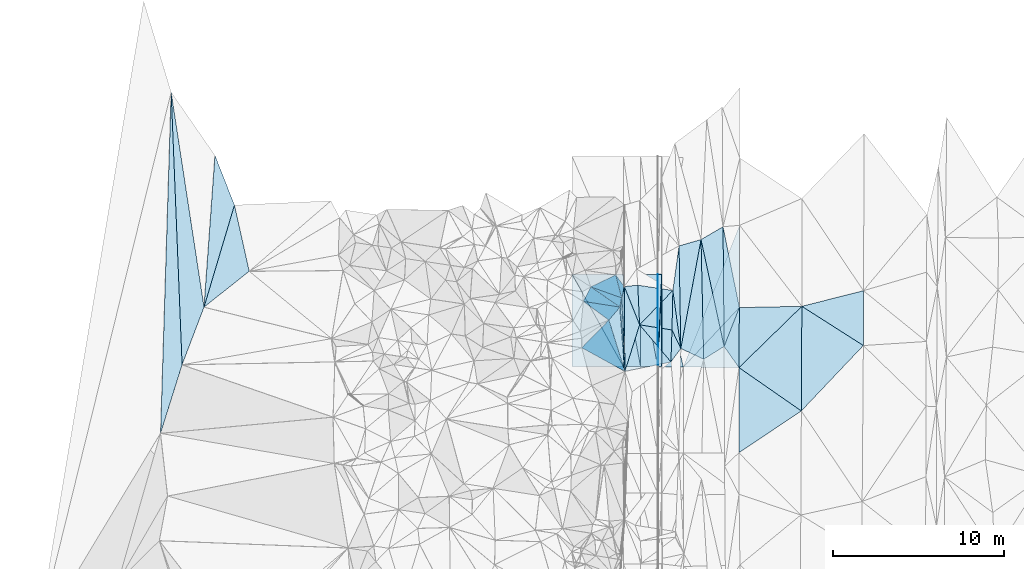
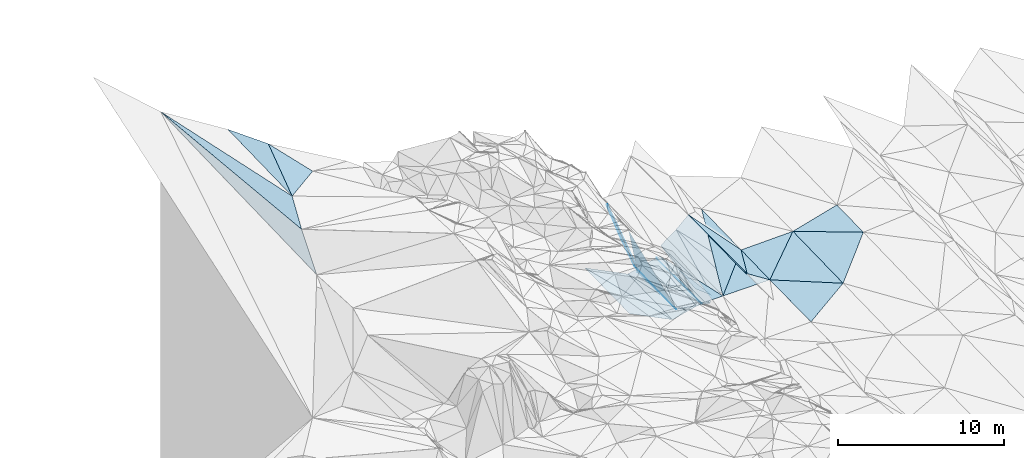
# One storey, part 140 of 275: 46 plates.
"""IFC2X3 building model written with IfcOpenShell, lengths in millimetres."""

import ifcopenshell
import ifcopenshell.guid

model = None  # the IFC model being written
_history = None  # IfcOwnerHistory: only IFC2X3 demands one
_inside = {}  # id of a spatial element -> (the spatial element, [elements in it])
_under = {}  # id of a project, library or spatial element -> (it, [spatial elements below it])
_declared = {}  # id of a project -> (the project, [libraries it declares])
_typed = {}  # id of a type object -> (the type object, [elements of that type])
_made_of = {}  # id of a material, layer set ... -> (it, [elements and type objects made of it])


def new_model(schema):
    """Start an empty IFC model of exactly this schema.

    Asked for "IFC4X3", IfcOpenShell would pick the latest addendum, in which some entities
    have other attributes; the version numbers below select the first issue.
    IFC2X3 requires an IfcOwnerHistory on every rooted entity: one is made here for all.
    """
    global model, _history
    if schema == "IFC4X3":
        model = ifcopenshell.file(schema_version=(4, 3, 0, 0))
    else:
        model = ifcopenshell.file(schema=schema)
    _inside.clear()
    _under.clear()
    _declared.clear()
    _typed.clear()
    _made_of.clear()
    _history = None
    if model.schema == "IFC2X3":
        org = make("IfcOrganization", Name="unknown")
        user = make(
            "IfcPersonAndOrganization",
            ThePerson=make("IfcPerson", FamilyName="unknown"),
            TheOrganization=org,
        )
        app = make(
            "IfcApplication",
            ApplicationDeveloper=org,
            Version="unknown",
            ApplicationFullName="unknown",
            ApplicationIdentifier="unknown",
        )
        _history = make(
            "IfcOwnerHistory",
            OwningUser=user,
            OwningApplication=app,
            ChangeAction="ADDED",
            CreationDate=0,
        )
    return model


def make(cls, **values):
    """One entity of the class cls with the attributes given. An attribute that is None is left unset."""
    return model.create_entity(
        cls, **{name: value for name, value in values.items() if value is not None}
    )


def rooted(cls, **values):
    """An entity with a GlobalId (a new one), such as an element, a storey or a relation."""
    return make(cls, GlobalId=ifcopenshell.guid.new(), OwnerHistory=_history, **values)


def si_unit(unit_type, name, prefix=None):
    """IfcSIUnit, for example si_unit("LENGTHUNIT", "METRE", prefix="MILLI")."""
    return make("IfcSIUnit", UnitType=unit_type, Prefix=prefix, Name=name)


def assignment(units):
    """IfcUnitAssignment: the units of a project."""
    return None if units is None else make("IfcUnitAssignment", Units=units)


def point(xyz):
    """IfcCartesianPoint."""
    return None if xyz is None else make("IfcCartesianPoint", Coordinates=xyz)


def direction(xyz):
    """IfcDirection."""
    return None if xyz is None else make("IfcDirection", DirectionRatios=xyz)


def frame(location, z_axis=None, x_axis=None):
    """IfcAxis2Placement3D, a coordinate frame: its origin and axes. An axis left out is left unset."""
    return make(
        "IfcAxis2Placement3D",
        Location=point(location),
        Axis=direction(z_axis),
        RefDirection=direction(x_axis),
    )


def origin_with_axes():
    """The frame at (0, 0, 0) with the z axis (0, 0, 1) and the x axis (1, 0, 0) written out."""
    return frame((0.0, 0.0, 0.0), z_axis=(0.0, 0.0, 1.0), x_axis=(1.0, 0.0, 0.0))


def place(relative_to, where):
    """IfcLocalPlacement: puts the frame where relative to a parent placement (None: the world)."""
    return make(
        "IfcLocalPlacement", PlacementRelTo=relative_to, RelativePlacement=where
    )


def context(
    kind, dimensions, precision=None, world=None, true_north=None, identifier=None
):
    """IfcGeometricRepresentationContext, for example the 3D "Model" context."""
    return make(
        "IfcGeometricRepresentationContext",
        ContextIdentifier=identifier,
        ContextType=kind,
        CoordinateSpaceDimension=dimensions,
        Precision=precision,
        WorldCoordinateSystem=world,
        TrueNorth=true_north,
    )


def subcontext(parent, identifier, kind, view, scale=None):
    """IfcGeometricRepresentationSubContext, for example "Body" below "Model"."""
    return make(
        "IfcGeometricRepresentationSubContext",
        ContextIdentifier=identifier,
        ContextType=kind,
        ParentContext=parent,
        TargetScale=scale,
        TargetView=view,
    )


def project(units=None, contexts=None):
    """IfcProject with its units and contexts."""
    return rooted(
        "IfcProject",
        Name="project",
        RepresentationContexts=contexts,
        UnitsInContext=assignment(units),
    )


def spatial(cls, under=None, at=None, **own):
    """A site, building, storey or space (cls), placed at a placement, below another one or the project."""
    s = rooted(cls, ObjectPlacement=at, **own)
    if under is not None:
        _under.setdefault(under.id(), (under, []))[1].append(s)
    return s


def polyline(points):
    """IfcPolyline through the points."""
    return make("IfcPolyline", Points=[point(p) for p in points])


def outline(outer, holes=None, kind="AREA"):
    """IfcArbitraryClosedProfileDef: a profile drawn as a closed curve; with holes, ...WithVoids."""
    if holes is None:
        return make("IfcArbitraryClosedProfileDef", ProfileType=kind, OuterCurve=outer)
    return make(
        "IfcArbitraryProfileDefWithVoids",
        ProfileType=kind,
        OuterCurve=outer,
        InnerCurves=holes,
    )


def extrude(swept, where, along, depth):
    """IfcExtrudedAreaSolid: the profile swept, set in the frame where, extruded along a direction by depth."""
    return make(
        "IfcExtrudedAreaSolid",
        SweptArea=swept,
        Position=where,
        ExtrudedDirection=direction(along),
        Depth=depth,
    )


def shape(context_of_items, identifier, shape_type, items):
    """IfcShapeRepresentation: the items that make up one representation, for example the "Body"."""
    return make(
        "IfcShapeRepresentation",
        ContextOfItems=context_of_items,
        RepresentationIdentifier=identifier,
        RepresentationType=shape_type,
        Items=items,
    )


def material(Name=None, Category=None):
    """IfcMaterial."""
    return make("IfcMaterial", Name=Name, Category=Category)


def made_of(thing, what):
    """Note that an element or type object is made of a material, layer set ...; save() writes the relation."""
    if what is not None:
        _made_of.setdefault(what.id(), (what, []))[1].append(thing)
    return thing


def type_object(cls, material=None, **own):
    """A type object (cls), such as IfcWallType, which elements share."""
    return made_of(rooted(cls, **own), material)


def element(
    cls,
    number,
    at=None,
    inside=None,
    cuts=None,
    type_object=None,
    material=None,
    context=None,
    identifier="Body",
    shape_type=None,
    held_by="IfcProductDefinitionShape",
    body=None,
    shapes=None,
    **own,
):
    """One element of the class cls, such as IfcWall. Its Tag is "e" and its number.

    at: its placement. inside: the storey or other place that contains it. cuts: it is an
    opening in that element (IfcRelVoidsElement). A single representation is given by context,
    identifier, shape_type and body (its items); several are given by shapes. held_by: the class
    of the entity that holds the representations. save() writes the other relations.
    """
    e = rooted(cls, Tag="e%d" % number, ObjectPlacement=at, **own)
    if body is not None:
        shapes = [shape(context, identifier, shape_type, body)]
    if shapes is not None:
        e.Representation = make(held_by, Representations=shapes)
    if inside is not None:
        _inside.setdefault(inside.id(), (inside, []))[1].append(e)
    if cuts is not None:
        rooted(
            "IfcRelVoidsElement", RelatingBuildingElement=cuts, RelatedOpeningElement=e
        )
    if type_object is not None:
        _typed.setdefault(type_object.id(), (type_object, []))[1].append(e)
    return made_of(e, material)


def aggregate(whole, parts):
    """IfcRelAggregates: a whole, such as a stair, and the parts it consists of."""
    return rooted("IfcRelAggregates", RelatingObject=whole, RelatedObjects=parts)


def save(model, path):
    """Write the relations noted so far, then the file.

    IfcRelAggregates (storeys below a building ...), IfcRelContainedInSpatialStructure (elements
    in a storey), IfcRelDefinesByType, IfcRelAssociatesMaterial and IfcRelDeclares: one each for
    every whole, place, type object, material and project.
    """
    for whole, parts in _under.values():
        aggregate(whole, parts)
    for where, things in _inside.values():
        rooted(
            "IfcRelContainedInSpatialStructure",
            RelatedElements=things,
            RelatingStructure=where,
        )
    for kind, things in _typed.values():
        rooted("IfcRelDefinesByType", RelatedObjects=things, RelatingType=kind)
    for what, things in _made_of.values():
        rooted("IfcRelAssociatesMaterial", RelatedObjects=things, RelatingMaterial=what)
    for by, libraries in _declared.values():
        rooted("IfcRelDeclares", RelatingContext=by, RelatedDefinitions=libraries)
    model.write(path)


model = new_model("IFC2X3")

# Units and contexts
model_context = context("Model", 3, precision=1e-05, world=origin_with_axes())
body_context = subcontext(model_context, "Body", "Model", "MODEL_VIEW")
ifc_project = project(units=[si_unit("LENGTHUNIT", "METRE", prefix="MILLI"), si_unit("AREAUNIT", "SQUARE_METRE"), si_unit("VOLUMEUNIT", "CUBIC_METRE"), si_unit("MASSUNIT", "GRAM", prefix="KILO"), si_unit("TIMEUNIT", "SECOND"), si_unit("PLANEANGLEUNIT", "RADIAN"), si_unit("SOLIDANGLEUNIT", "STERADIAN"), si_unit("THERMODYNAMICTEMPERATUREUNIT", "DEGREE_CELSIUS"), si_unit("LUMINOUSINTENSITYUNIT", "LUMEN")], contexts=[model_context])

# Site, building, storey
site_placement = place(None, origin_with_axes())
site = spatial("IfcSite", under=ifc_project, at=site_placement, CompositionType="ELEMENT")
building_placement = place(site_placement, origin_with_axes())
building = spatial("IfcBuilding", under=site, at=building_placement, Name="Undefined", CompositionType="ELEMENT")
storey_placement = place(building_placement, origin_with_axes())
storey = spatial("IfcBuildingStorey", under=building, at=storey_placement, Name="Undefined", CompositionType="ELEMENT", Elevation=0.0)

# Plates
ifc_material = material()
plate_type_1 = type_object("IfcPlateType", PredefinedType="NOTDEFINED")
plate_1_placement = place(storey_placement, frame((-95661.8990980026, 131994.425221321, 43600.5627120772), z_axis=(0.0499218416965569, 0.018987695683645, -0.998572619860093), x_axis=(0.998752315665235, 0.000325866070990781, 0.0499370179790064)))
element("IfcPlate", 1, at=plate_1_placement, inside=storey, type_object=plate_type_1, material=ifc_material, Name="00_PR", context=body_context, shape_type="SweptSolid", body=[
    extrude(outline(polyline([(0.0, 0.0), (20.0252170562744, 7.18500814400613e-11), (14.8728761672974, 5399.20458984375), (0.0, 0.0)])), frame((-8.85201319254618e-08, 2.18876761149539e-07, -0.5000001331573), z_axis=(0.0, 0.0, 1.0), x_axis=(1.0, 0.0, 0.0)), (0.0, 0.0, 1.0), 1.0),
])
plate_2_placement = place(storey_placement, frame((-95640.1682808377, 126596.199078681, 43499.002711449), z_axis=(0.0499218416965569, 0.018987695683645, -0.998572619860093), x_axis=(-0.998752315521962, -0.000325847078123489, -0.0499370209684242)))
element("IfcPlate", 2, at=plate_2_placement, inside=storey, type_object=plate_type_1, material=ifc_material, Name="00_PR", context=body_context, shape_type="SweptSolid", body=[
    extrude(outline(polyline([(0.0, 0.0), (20.0252170562744, 7.18500814400613e-11), (14.8730592727661, 5399.20458984375), (0.0, 0.0)])), frame((-8.85201319254618e-08, 2.18876761149539e-07, -0.5000001331573), z_axis=(0.0, 0.0, 1.0), x_axis=(1.0, 0.0, 0.0)), (0.0, 0.0, 1.0), 1.0),
])
plate_type_2 = type_object("IfcPlateType", PredefinedType="NOTDEFINED")
plate_3_placement = place(storey_placement, frame((-97863.179340422, 130077.496408482, 44289.6938578269), z_axis=(-0.790668284367022, -0.00121570864012599, -0.61224356766618), x_axis=(0.0757211073899815, -0.992514641650696, -0.0958175349538129)))
element("IfcPlate", 3, at=plate_3_placement, inside=storey, type_object=plate_type_2, material=ifc_material, Name="00", context=body_context, shape_type="SweptSolid", body=[
    extrude(outline(polyline([(0.0, 0.0), (3788.45068359375, -1.07684172689915e-09), (621.871643066406, 1146.20056152344), (0.0, 0.0)])), frame((-8.85201319254618e-08, 2.18876761149539e-07, -0.5000001331573), z_axis=(0.0, 0.0, 1.0), x_axis=(1.0, 0.0, 0.0)), (0.0, 0.0, 1.0), 1.0),
])
plate_type_3 = type_object("IfcPlateType", PredefinedType="NOTDEFINED")
plate_4_placement = place(storey_placement, frame((-120390.848597019, 136038.449160367, 58200.5032237032), z_axis=(-0.109542996135364, -0.030647323388409, -0.993509473315083), x_axis=(0.218084760553901, -0.975911025166168, 0.00605872703353124)))
element("IfcPlate", 4, at=plate_4_placement, inside=storey, type_object=plate_type_3, material=ifc_material, Name="00", context=body_context, shape_type="SweptSolid", body=[
    extrude(outline(polyline([(0.0, 0.0), (3961.22827148438, -4.1094608604908e-08), (5431.02783203125, 3055.7373046875), (0.0, 0.0)])), frame((-8.85201319254618e-08, 2.18876761149539e-07, -0.5000001331573), z_axis=(0.0, 0.0, 1.0), x_axis=(1.0, 0.0, 0.0)), (0.0, 0.0, 1.0), 1.0),
])
plate_type_4 = type_object("IfcPlateType", PredefinedType="NOTDEFINED")
for number, where, z_axis, x_axis, name in (
    (5, (-95640.1682808377, 126596.199078681, 43499.002711449), (0.0499218416965569, 0.018987695683645, -0.998572619860093), (0.0422380869159654, 0.9988846335438, 0.0211052809445606), "00_PR"),
    (6, (-95411.8995216493, 131994.505833605, 43613.0627106872), (0.0499218416965569, 0.018987695683645, -0.998572619860093), (-0.042238086915738, -0.998884633543988, -0.0211052809360945), "00_PR"),
):
    element("IfcPlate", number, at=place(storey_placement, frame(where, z_axis=z_axis, x_axis=x_axis)), inside=storey, type_object=plate_type_4, material=ifc_material, Name=name, context=body_context, shape_type="SweptSolid", body=[
        extrude(outline(polyline([(0.0, 0.0), (5404.33447265625, -3.89991328120232e-09), (10.0314474105835, 230.068084716797), (0.0, 0.0)])), frame((-8.85201319254618e-08, 2.18876761149539e-07, -0.5000001331573), z_axis=(0.0, 0.0, 1.0), x_axis=(1.0, 0.0, 0.0)), (0.0, 0.0, 1.0), 1.0),
    ])
plate_type_5 = type_object("IfcPlateType", PredefinedType="NOTDEFINED")
plate_5_placement = place(storey_placement, frame((-94823.4613389008, 128742.419038902, 42979.5019184883), z_axis=(-0.0783408175481711, -0.04016436048198, -0.99611723228391), x_axis=(0.430857008612677, -0.902416745782213, 0.00250101203026424)))
element("IfcPlate", 7, at=plate_5_placement, inside=storey, type_object=plate_type_5, material=ifc_material, Name="00", context=body_context, shape_type="SweptSolid", body=[
    extrude(outline(polyline([(0.0, 0.0), (1199.51452636719, -4.60568116977811e-09), (1655.84497070313, 862.019409179688), (0.0, 0.0)])), frame((-8.85201319254618e-08, 2.18876761149539e-07, -0.5000001331573), z_axis=(0.0, 0.0, 1.0), x_axis=(1.0, 0.0, 0.0)), (0.0, 0.0, 1.0), 1.0),
])
plate_type_6 = type_object("IfcPlateType", PredefinedType="NOTDEFINED")
plate_6_placement = place(storey_placement, frame((-100662.146809664, 131992.821665722, 44600.6148496057), z_axis=(-0.447154492281629, 0.0168472491289806, -0.894298065652132), x_axis=(0.894427130836624, 0.000286740053144665, -0.447213623901941)))
element("IfcPlate", 8, at=plate_6_placement, inside=storey, type_object=plate_type_6, material=ifc_material, Name="00_PR", context=body_context, shape_type="SweptSolid", body=[
    extrude(outline(polyline([(0.0, 0.0), (3354.10180664063, 1.95868778973818e-08), (3399.96801757813, 5399.01220703125), (0.0, 0.0)])), frame((-8.85201319254618e-08, 2.18876761149539e-07, -0.5000001331573), z_axis=(0.0, 0.0, 1.0), x_axis=(1.0, 0.0, 0.0)), (0.0, 0.0, 1.0), 1.0),
])
plate_7_placement = place(storey_placement, frame((-97660.4166155933, 126595.550751445, 42998.0548495893), z_axis=(-0.447154492281629, 0.0168472491289806, -0.894298065652132), x_axis=(-0.894427130836978, -0.000286740047867567, 0.447213623901237)))
element("IfcPlate", 9, at=plate_7_placement, inside=storey, type_object=plate_type_6, material=ifc_material, Name="00_PR", context=body_context, shape_type="SweptSolid", body=[
    extrude(outline(polyline([(0.0, 0.0), (3354.1025390625, 9.64791979640722e-09), (3399.96728515625, 5399.0126953125), (0.0, 0.0)])), frame((-8.85201319254618e-08, 2.18876761149539e-07, -0.5000001331573), z_axis=(0.0, 0.0, 1.0), x_axis=(1.0, 0.0, 0.0)), (0.0, 0.0, 1.0), 1.0),
])
plate_type_7 = type_object("IfcPlateType", PredefinedType="NOTDEFINED")
plate_8_placement = place(storey_placement, frame((-96660.0726741752, 126595.872203827, 43248.0170096413), z_axis=(0.242488705228662, 0.0185061610069776, -0.969977705847568), x_axis=(-0.970142403271045, -0.000311047105442569, -0.242535813077531)))
element("IfcPlate", 10, at=plate_8_placement, inside=storey, type_object=plate_type_7, material=ifc_material, Name="00_PR", context=body_context, shape_type="SweptSolid", body=[
    extrude(outline(polyline([(0.0, 0.0), (1030.77563476563, 6.37373887002468e-09), (1005.90093994141, 5399.14990234375), (0.0, 0.0)])), frame((-8.85201319254618e-08, 2.18876761149539e-07, -0.5000001331573), z_axis=(0.0, 0.0, 1.0), x_axis=(1.0, 0.0, 0.0)), (0.0, 0.0, 1.0), 1.0),
])
plate_9_placement = place(storey_placement, frame((-95660.0722308411, 126596.192312802, 43498.0170093509), z_axis=(0.242488705228662, 0.0185061610069776, -0.969977705847568), x_axis=(-0.970142403271045, -0.000311047105442569, -0.242535813077531)))
element("IfcPlate", 11, at=plate_9_placement, inside=storey, type_object=plate_type_7, material=ifc_material, Name="00_PR", context=body_context, shape_type="SweptSolid", body=[
    extrude(outline(polyline([(0.0, 0.0), (1030.77685546875, 5.06406649947166e-09), (1005.90490722656, 5399.14990234375), (0.0, 0.0)])), frame((-8.85201319254618e-08, 2.18876761149539e-07, -0.5000001331573), z_axis=(0.0, 0.0, 1.0), x_axis=(1.0, 0.0, 0.0)), (0.0, 0.0, 1.0), 1.0),
])
plate_10_placement = place(storey_placement, frame((-97661.8023938681, 131993.784248121, 43100.5770082104), z_axis=(0.242488705228662, 0.0185061610069776, -0.969977705847568), x_axis=(0.970142455388523, 0.000311440077304942, 0.242535604103411)))
element("IfcPlate", 12, at=plate_10_placement, inside=storey, type_object=plate_type_7, material=ifc_material, Name="00_PR", context=body_context, shape_type="SweptSolid", body=[
    extrude(outline(polyline([(0.0, 0.0), (1030.77563476563, 6.37373887002468e-09), (1005.90093994141, 5399.14990234375), (0.0, 0.0)])), frame((-8.85201319254618e-08, 2.18876761149539e-07, -0.5000001331573), z_axis=(0.0, 0.0, 1.0), x_axis=(1.0, 0.0, 0.0)), (0.0, 0.0, 1.0), 1.0),
])
plate_11_placement = place(storey_placement, frame((-95660.0722308411, 126596.192312802, 43498.0170093509), z_axis=(0.242488705228662, 0.0185061610069776, -0.969977705847568), x_axis=(-0.182396408137149, 0.982858504377498, -0.0268460550452826)))
element("IfcPlate", 13, at=plate_11_placement, inside=storey, type_object=plate_type_7, material=ifc_material, Name="00_PR", context=body_context, shape_type="SweptSolid", body=[
    extrude(outline(polyline([(0.0, 0.0), (5492.0546875, 2.69646989181638e-08), (5303.26123046875, 1013.34002685547), (0.0, 0.0)])), frame((-8.85201319254618e-08, 2.18876761149539e-07, -0.5000001331573), z_axis=(0.0, 0.0, 1.0), x_axis=(1.0, 0.0, 0.0)), (0.0, 0.0, 1.0), 1.0),
])
plate_type_8 = type_object("IfcPlateType", PredefinedType="NOTDEFINED")
plate_12_placement = place(storey_placement, frame((-97612.1278846414, 131282.944115251, 44127.663024008), z_axis=(-0.738487986327244, 0.0219489512718493, -0.673909294778161), x_axis=(0.00721172458118886, -0.999155744242152, -0.0404448980277686)))
element("IfcPlate", 14, at=plate_12_placement, inside=storey, type_object=plate_type_8, material=ifc_material, Name="00", context=body_context, shape_type="SweptSolid", body=[
    extrude(outline(polyline([(0.0, 0.0), (4969.724609375, -5.40312612429261e-08), (661.130981445313, 228.735198974609), (0.0, 0.0)])), frame((-8.85201319254618e-08, 2.18876761149539e-07, -0.5000001331573), z_axis=(0.0, 0.0, 1.0), x_axis=(1.0, 0.0, 0.0)), (0.0, 0.0, 1.0), 1.0),
])
plate_type_9 = type_object("IfcPlateType", PredefinedType="NOTDEFINED")
plate_13_placement = place(storey_placement, frame((-94160.1732957976, 126572.965089618, 43538.2812143713), z_axis=(0.0225676012123619, 0.0189977767902863, -0.999564799226417), x_axis=(-0.999579491036993, 0.0186384849298618, -0.0222136889719966)))
element("IfcPlate", 15, at=plate_13_placement, inside=storey, type_object=plate_type_9, material=ifc_material, Name="00_PR", context=body_context, shape_type="SweptSolid", body=[
    extrude(outline(polyline([(0.0, 0.0), (1250.53515625, 2.48837750405073e-09), (1350.60168457031, 5398.27978515625), (0.0, 0.0)])), frame((-8.85201319254618e-08, 2.18876761149539e-07, -0.5000001331573), z_axis=(0.0, 0.0, 1.0), x_axis=(1.0, 0.0, 0.0)), (0.0, 0.0, 1.0), 1.0),
])
plate_type_10 = type_object("IfcPlateType", PredefinedType="NOTDEFINED")
plate_14_placement = place(storey_placement, frame((-90868.8061363203, 134858.756942, 43772.0302122336), z_axis=(0.0220145554295326, 0.0194537974897408, -0.999568361400294), x_axis=(-0.00365214192346392, -0.99980242929502, -0.019538787965144)))
element("IfcPlate", 16, at=plate_14_placement, inside=storey, type_object=plate_type_10, material=ifc_material, Name="00_PR", context=body_context, shape_type="SweptSolid", body=[
    extrude(outline(polyline([(0.0, 0.0), (4808.5888671875, -6.93980837240815e-08), (8300.7421875, 3261.8642578125), (0.0, 0.0)])), frame((-8.85201319254618e-08, 2.18876761149539e-07, -0.5000001331573), z_axis=(0.0, 0.0, 1.0), x_axis=(1.0, 0.0, 0.0)), (0.0, 0.0, 1.0), 1.0),
])
plate_type_11 = type_object("IfcPlateType", PredefinedType="NOTDEFINED")
plate_15_placement = place(storey_placement, frame((-90886.3677518912, 130051.118030396, 43678.0762124378), z_axis=(0.0220835300894466, 0.0193888651768907, -0.999568101534828), x_axis=(-0.0065915929099637, -0.999787371529886, -0.0195387469473334)))
element("IfcPlate", 17, at=plate_15_placement, inside=storey, type_object=plate_type_11, material=ifc_material, Name="00_PR", context=body_context, shape_type="SweptSolid", body=[
    extrude(outline(polyline([(0.0, 0.0), (3509.74389648438, 1.25291990116239e-08), (3501.72412109375, 3251.58740234375), (0.0, 0.0)])), frame((-8.85201319254618e-08, 2.18876761149539e-07, -0.5000001331573), z_axis=(0.0, 0.0, 1.0), x_axis=(1.0, 0.0, 0.0)), (0.0, 0.0, 1.0), 1.0),
])
plate_type_12 = type_object("IfcPlateType", PredefinedType="NOTDEFINED")
plate_16_placement = place(storey_placement, frame((-98114.4141413349, 131956.453214629, 45819.834015457), z_axis=(-0.933140588245318, 0.138105686779731, -0.331926892324623), x_axis=(0.265838928305538, -0.356498279862591, -0.895677754916564)))
element("IfcPlate", 18, at=plate_16_placement, inside=storey, type_object=plate_type_12, material=ifc_material, Name="00", context=body_context, shape_type="SweptSolid", body=[
    extrude(outline(polyline([(0.0, 0.0), (1889.072265625, -2.7212081477046e-09), (1960.48083496094, 695.927307128906), (0.0, 0.0)])), frame((-8.85201319254618e-08, 2.18876761149539e-07, -0.5000001331573), z_axis=(0.0, 0.0, 1.0), x_axis=(1.0, 0.0, 0.0)), (0.0, 0.0, 1.0), 1.0),
])
plate_type_13 = type_object("IfcPlateType", PredefinedType="NOTDEFINED")
plate_17_placement = place(storey_placement, frame((-97863.2443082038, 130077.580927324, 44289.8236715138), z_axis=(-0.920595210166484, 0.167829841706515, -0.352615375801019), x_axis=(-0.348481156374074, 0.0544786368970685, 0.935731244414776)))
element("IfcPlate", 19, at=plate_17_placement, inside=storey, type_object=plate_type_13, material=ifc_material, Name="00", context=body_context, shape_type="SweptSolid", body=[
    extrude(outline(polyline([(0.0, 0.0), (6134.23974609375, 1.1146767064929e-08), (5346.04150390625, 905.120300292969), (0.0, 0.0)])), frame((-8.85201319254618e-08, 2.18876761149539e-07, -0.5000001331573), z_axis=(0.0, 0.0, 1.0), x_axis=(1.0, 0.0, 0.0)), (0.0, 0.0, 1.0), 1.0),
])
plate_type_14 = type_object("IfcPlateType", PredefinedType="NOTDEFINED")
plate_18_placement = place(storey_placement, frame((-94411.4847820589, 133654.498374057, 43059.5079749297), z_axis=(-0.177884222103543, 0.00952994301497235, -0.984005276262657), x_axis=(0.0174773486148488, -0.999764784341978, -0.0128420510446195)))
element("IfcPlate", 20, at=plate_18_placement, inside=storey, type_object=plate_type_14, material=ifc_material, Name="00", context=body_context, shape_type="SweptSolid", body=[
    extrude(outline(polyline([(0.0, 0.0), (5995.9267578125, -4.41359588876367e-08), (2596.8369140625, 412.823272705078), (0.0, 0.0)])), frame((-8.85201319254618e-08, 2.18876761149539e-07, -0.5000001331573), z_axis=(0.0, 0.0, 1.0), x_axis=(1.0, 0.0, 0.0)), (0.0, 0.0, 1.0), 1.0),
])
plate_type_15 = type_object("IfcPlateType", PredefinedType="NOTDEFINED")
plate_19_placement = place(storey_placement, frame((-96716.6297522672, 129042.645744843, 43779.5308324078), z_axis=(-0.345445783626743, 0.016738339117702, -0.938289421542248), x_axis=(-0.0453271786313886, 0.998376344303925, 0.034498145046499)))
element("IfcPlate", 21, at=plate_19_placement, inside=storey, type_object=plate_type_15, material=ifc_material, Name="00", context=body_context, shape_type="SweptSolid", body=[
    extrude(outline(polyline([(0.0, 0.0), (2318.96533203125, -3.18686943501234e-09), (1892.74072265625, 2165.763671875), (0.0, 0.0)])), frame((-8.85201319254618e-08, 2.18876761149539e-07, -0.5000001331573), z_axis=(0.0, 0.0, 1.0), x_axis=(1.0, 0.0, 0.0)), (0.0, 0.0, 1.0), 1.0),
])
plate_type_16 = type_object("IfcPlateType", PredefinedType="NOTDEFINED")
plate_20_placement = place(storey_placement, frame((-97761.4351360014, 130614.442654695, 44269.5540765426), z_axis=(-0.449444516817921, 0.0518058851599099, -0.891804786130408), x_axis=(0.0429447604263251, -0.995909669650746, -0.0794963989628941)))
element("IfcPlate", 22, at=plate_20_placement, inside=storey, type_object=plate_type_16, material=ifc_material, Name="00", context=body_context, shape_type="SweptSolid", body=[
    extrude(outline(polyline([(0.0, 0.0), (4314.66064453125, -1.19616743177176e-08), (528.771545410156, 139.286117553711), (0.0, 0.0)])), frame((-8.85201319254618e-08, 2.18876761149539e-07, -0.5000001331573), z_axis=(0.0, 0.0, 1.0), x_axis=(1.0, 0.0, 0.0)), (0.0, 0.0, 1.0), 1.0),
])
plate_type_17 = type_object("IfcPlateType", PredefinedType="NOTDEFINED")
plate_21_placement = place(storey_placement, frame((-100000.884340665, 130411.862898079, 50029.8280838471), z_axis=(-0.866591819289739, 0.361699447843314, -0.343790820368931), x_axis=(0.348481156364522, -0.0544786368875606, -0.935731244418887)))
element("IfcPlate", 23, at=plate_21_placement, inside=storey, type_object=plate_type_17, material=ifc_material, Name="00", context=body_context, shape_type="SweptSolid", body=[
    extrude(outline(polyline([(0.0, 0.0), (6134.23974609375, 1.1146767064929e-08), (5163.21484375, 870.408264160156), (0.0, 0.0)])), frame((-8.85201319254618e-08, 2.18876761149539e-07, -0.5000001331573), z_axis=(0.0, 0.0, 1.0), x_axis=(1.0, 0.0, 0.0)), (0.0, 0.0, 1.0), 1.0),
])
plate_type_18 = type_object("IfcPlateType", PredefinedType="NOTDEFINED")
plate_22_placement = place(storey_placement, frame((-121530.375943407, 138942.628059413, 57899.5024330567), z_axis=(0.0574518510758072, -0.0805898677710441, -0.995090226070284), x_axis=(0.363595682353046, -0.926593490568315, 0.0960348010392524)))
element("IfcPlate", 24, at=plate_22_placement, inside=storey, type_object=plate_type_18, material=ifc_material, Name="00", context=body_context, shape_type="SweptSolid", body=[
    extrude(outline(polyline([(0.0, 0.0), (3134.28051757813, -3.46481101587415e-08), (8046.7021484375, 3834.28002929688), (0.0, 0.0)])), frame((-8.85201319254618e-08, 2.18876761149539e-07, -0.5000001331573), z_axis=(0.0, 0.0, 1.0), x_axis=(1.0, 0.0, 0.0)), (0.0, 0.0, 1.0), 1.0),
])
plate_type_19 = type_object("IfcPlateType", PredefinedType="NOTDEFINED")
plate_23_placement = place(storey_placement, frame((-97761.6712142153, 130614.498777309, 44269.824096593), z_axis=(-0.921600901149196, 0.164052323724709, -0.351764998374643), x_axis=(-0.335329305244169, 0.119869627865135, 0.93444396801517)))
element("IfcPlate", 25, at=plate_23_placement, inside=storey, type_object=plate_type_19, material=ifc_material, Name="00", context=body_context, shape_type="SweptSolid", body=[
    extrude(outline(polyline([(0.0, 0.0), (5382.88037109375, 1.74622982740402e-10), (1727.53234863281, 1159.06506347656), (0.0, 0.0)])), frame((-8.85201319254618e-08, 2.18876761149539e-07, -0.5000001331573), z_axis=(0.0, 0.0, 1.0), x_axis=(1.0, 0.0, 0.0)), (0.0, 0.0, 1.0), 1.0),
])
plate_type_20 = type_object("IfcPlateType", PredefinedType="NOTDEFINED")
plate_24_placement = place(storey_placement, frame((-99566.7089818118, 131259.741281314, 49299.8241732481), z_axis=(-0.922136537378916, 0.161350960328072, -0.351610685321182), x_axis=(0.335329305241263, -0.11986962787173, -0.934443968015368)))
element("IfcPlate", 26, at=plate_24_placement, inside=storey, type_object=plate_type_20, material=ifc_material, Name="00", context=body_context, shape_type="SweptSolid", body=[
    extrude(outline(polyline([(0.0, 0.0), (5382.88037109375, 1.74622982740402e-10), (5394.4912109375, 546.685668945313), (0.0, 0.0)])), frame((-8.85201319254618e-08, 2.18876761149539e-07, -0.5000001331573), z_axis=(0.0, 0.0, 1.0), x_axis=(1.0, 0.0, 0.0)), (0.0, 0.0, 1.0), 1.0),
])
plate_type_21 = type_object("IfcPlateType", PredefinedType="NOTDEFINED")
plate_25_placement = place(storey_placement, frame((-91839.3835040095, 134774.053365125, 43750.5049821204), z_axis=(0.139610951164466, 0.0193680825755474, -0.990016999698642), x_axis=(0.00896495154188279, -0.999792437992992, -0.0182950970448627)))
element("IfcPlate", 27, at=plate_25_placement, inside=storey, type_object=plate_type_21, material=ifc_material, Name="00", context=body_context, shape_type="SweptSolid", body=[
    extrude(outline(polyline([(0.0, 0.0), (6996.41015625, 9.33068804442883e-08), (740.8359375, 1305.46704101563), (0.0, 0.0)])), frame((-8.85201319254618e-08, 2.18876761149539e-07, -0.5000001331573), z_axis=(0.0, 0.0, 1.0), x_axis=(1.0, 0.0, 0.0)), (0.0, 0.0, 1.0), 1.0),
])
plate_type_22 = type_object("IfcPlateType", PredefinedType="NOTDEFINED")
plate_26_placement = place(storey_placement, frame((-91776.6520885695, 127779.097419684, 43622.5063666759), z_axis=(0.157485388504728, 0.0232578790326317, -0.987247397297364), x_axis=(-0.839480931776968, -0.523340068493708, -0.146242736202095)))
element("IfcPlate", 28, at=plate_26_placement, inside=storey, type_object=plate_type_22, material=ifc_material, Name="00", context=body_context, shape_type="SweptSolid", body=[
    extrude(outline(polyline([(0.0, 0.0), (1422.29284667969, -8.70204530656338e-09), (-2126.6337890625, 6026.10009765625), (0.0, 0.0)])), frame((-8.85201319254618e-08, 2.18876761149539e-07, -0.5000001331573), z_axis=(0.0, 0.0, 1.0), x_axis=(1.0, 0.0, 0.0)), (0.0, 0.0, 1.0), 1.0),
])
plate_type_23 = type_object("IfcPlateType", PredefinedType="NOTDEFINED")
plate_27_placement = place(storey_placement, frame((-97611.9200057118, 131282.942163033, 44127.5268126904), z_axis=(-0.322670673594053, 0.018050502676152, -0.946339165286684), x_axis=(0.943222205319962, 0.0894107475447204, -0.319902468910199)))
element("IfcPlate", 29, at=plate_27_placement, inside=storey, type_object=plate_type_23, material=ifc_material, Name="00", context=body_context, shape_type="SweptSolid", body=[
    extrude(outline(polyline([(0.0, 0.0), (837.755310058594, -7.8580342233181e-10), (755.487854003906, 2317.50561523438), (0.0, 0.0)])), frame((-8.85201319254618e-08, 2.18876761149539e-07, -0.5000001331573), z_axis=(0.0, 0.0, 1.0), x_axis=(1.0, 0.0, 0.0)), (0.0, 0.0, 1.0), 1.0),
])
plate_type_24 = type_object("IfcPlateType", PredefinedType="NOTDEFINED")
plate_28_placement = place(storey_placement, frame((-98512.5232579481, 129320.235740806, 45129.8187090364), z_axis=(-0.921100322758629, -0.141911802888743, -0.362539977953903), x_axis=(0.277982332373289, -0.891693451741868, -0.357223474885091)))
element("IfcPlate", 30, at=plate_28_placement, inside=storey, type_object=plate_type_24, material=ifc_material, Name="00", context=body_context, shape_type="SweptSolid", body=[
    extrude(outline(polyline([(0.0, 0.0), (3367.63989257813, -8.35643731988966e-09), (-658.369079589844, 5128.80615234375), (0.0, 0.0)])), frame((-8.85201319254618e-08, 2.18876761149539e-07, -0.5000001331573), z_axis=(0.0, 0.0, 1.0), x_axis=(1.0, 0.0, 0.0)), (0.0, 0.0, 1.0), 1.0),
])
plate_type_25 = type_object("IfcPlateType", PredefinedType="NOTDEFINED")
plate_29_placement = place(storey_placement, frame((-94772.130848077, 131050.24941395, 43099.5035568534), z_axis=(0.108830829938251, 0.0492094342918905, -0.992841519091352), x_axis=(0.135973483617643, -0.99012303792608, -0.0341698920237095)))
element("IfcPlate", 31, at=plate_29_placement, inside=storey, type_object=plate_type_25, material=ifc_material, Name="00", context=body_context, shape_type="SweptSolid", body=[
    extrude(outline(polyline([(0.0, 0.0), (3424.06713867188, 1.94850144907832e-08), (2282.12524414063, 367.156768798828), (0.0, 0.0)])), frame((-8.85201319254618e-08, 2.18876761149539e-07, -0.5000001331573), z_axis=(0.0, 0.0, 1.0), x_axis=(1.0, 0.0, 0.0)), (0.0, 0.0, 1.0), 1.0),
])
plate_type_26 = type_object("IfcPlateType", PredefinedType="NOTDEFINED")
plate_30_placement = place(storey_placement, frame((-90886.3704720885, 130051.117575946, 43679.5001458232), z_axis=(0.016931200733731, 0.0184449776609478, -0.999686509482248), x_axis=(-0.364761661355905, -0.930808046182644, -0.0233519071283115)))
element("IfcPlate", 32, at=plate_30_placement, inside=storey, type_object=plate_type_26, material=ifc_material, Name="00", context=body_context, shape_type="SweptSolid", body=[
    extrude(outline(polyline([(0.0, 0.0), (2440.9140625, 9.80799086391926e-09), (-4050.1591796875, 2610.693359375), (0.0, 0.0)])), frame((-8.85201319254618e-08, 2.18876761149539e-07, -0.5000001331573), z_axis=(0.0, 0.0, 1.0), x_axis=(1.0, 0.0, 0.0)), (0.0, 0.0, 1.0), 1.0),
])
plate_type_27 = type_object("IfcPlateType", PredefinedType="NOTDEFINED")
plate_31_placement = place(storey_placement, frame((-94306.4256884343, 127659.986263894, 42982.5325690659), z_axis=(0.354599086255454, 0.0182070122824147, -0.934841159090968), x_axis=(-0.0174773485467523, 0.999764784343175, 0.0128420510441466)))
element("IfcPlate", 33, at=plate_31_placement, inside=storey, type_object=plate_type_27, material=ifc_material, Name="00", context=body_context, shape_type="SweptSolid", body=[
    extrude(outline(polyline([(0.0, 0.0), (5995.9267578125, -4.41359588876367e-08), (6350.3369140625, 1382.19226074219), (0.0, 0.0)])), frame((-8.85201319254618e-08, 2.18876761149539e-07, -0.5000001331573), z_axis=(0.0, 0.0, 1.0), x_axis=(1.0, 0.0, 0.0)), (0.0, 0.0, 1.0), 1.0),
])
plate_type_28 = type_object("IfcPlateType", PredefinedType="NOTDEFINED")
plate_32_placement = place(storey_placement, frame((-92970.5592850116, 127034.755967174, 43414.5262166441), z_axis=(0.318596530682224, 0.0260284667363977, -0.947532991276084), x_axis=(-0.869194716772744, 0.406809355320055, -0.281081292081901)))
element("IfcPlate", 34, at=plate_32_placement, inside=storey, type_object=plate_type_28, material=ifc_material, Name="00", context=body_context, shape_type="SweptSolid", body=[
    extrude(outline(polyline([(0.0, 0.0), (1536.921875, -1.10594555735588e-09), (2938.87866210938, 6346.0029296875), (0.0, 0.0)])), frame((-8.85201319254618e-08, 2.18876761149539e-07, -0.5000001331573), z_axis=(0.0, 0.0, 1.0), x_axis=(1.0, 0.0, 0.0)), (0.0, 0.0, 1.0), 1.0),
])
plate_type_29 = type_object("IfcPlateType", PredefinedType="NOTDEFINED")
plate_33_placement = place(storey_placement, frame((-90909.5070740503, 126542.120591966, 43609.5001316518), z_axis=(0.0133345821571376, 0.0198550951144349, -0.999713941143511), x_axis=(-0.574033813648268, 0.818786378759345, 0.00860504192805664)))
element("IfcPlate", 35, at=plate_33_placement, inside=storey, type_object=plate_type_29, material=ifc_material, Name="00", context=body_context, shape_type="SweptSolid", body=[
    extrude(outline(polyline([(0.0, 0.0), (1510.7421875, -1.7234924598597e-09), (2860.44165039063, 2033.8076171875), (0.0, 0.0)])), frame((-8.85201319254618e-08, 2.18876761149539e-07, -0.5000001331573), z_axis=(0.0, 0.0, 1.0), x_axis=(1.0, 0.0, 0.0)), (0.0, 0.0, 1.0), 1.0),
])
plate_type_30 = type_object("IfcPlateType", PredefinedType="NOTDEFINED")
plate_34_placement = place(storey_placement, frame((-96716.5973935263, 129042.65577561, 43779.5204344154), z_axis=(-0.28071667389583, 0.0367967112534563, -0.959085059334047), x_axis=(-0.300371837446863, -0.952437603351049, 0.0513748089213619)))
element("IfcPlate", 36, at=plate_34_placement, inside=storey, type_object=plate_type_30, material=ifc_material, Name="00", context=body_context, shape_type="SweptSolid", body=[
    extrude(outline(polyline([(0.0, 0.0), (2861.32446289063, 3.20142135024071e-09), (-1846.94006347656, 1590.72509765625), (0.0, 0.0)])), frame((-8.85201319254618e-08, 2.18876761149539e-07, -0.5000001331573), z_axis=(0.0, 0.0, 1.0), x_axis=(1.0, 0.0, 0.0)), (0.0, 0.0, 1.0), 1.0),
])
plate_type_31 = type_object("IfcPlateType", PredefinedType="NOTDEFINED")
plate_35_placement = place(storey_placement, frame((-94885.1530728616, 126878.367535568, 43059.5403333033), z_axis=(-0.39269350196078, -0.0264899457799151, -0.919287820157733), x_axis=(-0.626110959512704, 0.739865981591093, 0.246136944935801)))
element("IfcPlate", 37, at=plate_35_placement, inside=storey, type_object=plate_type_31, material=ifc_material, Name="00", context=body_context, shape_type="SweptSolid", body=[
    extrude(outline(polyline([(0.0, 0.0), (2925.20092773438, 2.73212208412588e-09), (1320.93493652344, 1319.10229492188), (0.0, 0.0)])), frame((-8.85201319254618e-08, 2.18876761149539e-07, -0.5000001331573), z_axis=(0.0, 0.0, 1.0), x_axis=(1.0, 0.0, 0.0)), (0.0, 0.0, 1.0), 1.0),
])
plate_type_32 = type_object("IfcPlateType", PredefinedType="NOTDEFINED")
plate_36_placement = place(storey_placement, frame((-96716.6475560677, 129042.665600488, 43779.5385598939), z_axis=(-0.381040175987767, 0.056445181093853, -0.922833856018782), x_axis=(0.675966942775388, 0.697979963649057, -0.236416290934773)))
element("IfcPlate", 38, at=plate_36_placement, inside=storey, type_object=plate_type_32, material=ifc_material, Name="00", context=body_context, shape_type="SweptSolid", body=[
    extrude(outline(polyline([(0.0, 0.0), (2876.2822265625, -2.03726813197136e-09), (1259.22961425781, 1651.67810058594), (0.0, 0.0)])), frame((-8.85201319254618e-08, 2.18876761149539e-07, -0.5000001331573), z_axis=(0.0, 0.0, 1.0), x_axis=(1.0, 0.0, 0.0)), (0.0, 0.0, 1.0), 1.0),
])
plate_type_33 = type_object("IfcPlateType", PredefinedType="NOTDEFINED")
plate_37_placement = place(storey_placement, frame((-94885.114440024, 126878.404958694, 43059.5261185984), z_axis=(-0.315425416783504, 0.0483560342857458, -0.947717521414007), x_axis=(-0.93361581031173, -0.194628008710008, 0.300801357978234)))
element("IfcPlate", 39, at=plate_37_placement, inside=storey, type_object=plate_type_33, material=ifc_material, Name="00", context=body_context, shape_type="SweptSolid", body=[
    extrude(outline(polyline([(0.0, 0.0), (2882.30078125, -6.08270056545734e-09), (1505.26965332031, 2508.17919921875), (0.0, 0.0)])), frame((-8.85201319254618e-08, 2.18876761149539e-07, -0.5000001331573), z_axis=(0.0, 0.0, 1.0), x_axis=(1.0, 0.0, 0.0)), (0.0, 0.0, 1.0), 1.0),
])
plate_type_34 = type_object("IfcPlateType", PredefinedType="NOTDEFINED")
plate_38_placement = place(storey_placement, frame((-90909.5067983085, 126542.118687155, 43609.5001013182), z_axis=(0.0138889990748666, 0.0160447255908551, -0.999774805886512), x_axis=(0.821269150479754, -0.570536507514277, 0.00225301213366851)))
element("IfcPlate", 40, at=plate_38_placement, inside=storey, type_object=plate_type_34, material=ifc_material, Name="00", context=body_context, shape_type="SweptSolid", body=[
    extrude(outline(polyline([(0.0, 0.0), (4438.501953125, -6.83940015733242e-09), (2833.72631835938, 4093.81176757813), (0.0, 0.0)])), frame((-8.85201319254618e-08, 2.18876761149539e-07, -0.5000001331573), z_axis=(0.0, 0.0, 1.0), x_axis=(1.0, 0.0, 0.0)), (0.0, 0.0, 1.0), 1.0),
])
plate_type_35 = type_object("IfcPlateType", PredefinedType="NOTDEFINED")
plate_39_placement = place(storey_placement, frame((-90886.3722939975, 130051.118280741, 43679.5001318194), z_axis=(0.0132888260168211, 0.0198554092018989, -0.999714544171745), x_axis=(0.999706452219784, 0.019992708658956, 0.013685795212928)))
element("IfcPlate", 41, at=plate_39_placement, inside=storey, type_object=plate_type_35, material=ifc_material, Name="00", context=body_context, shape_type="SweptSolid", body=[
    extrude(outline(polyline([(0.0, 0.0), (3653.42309570313, 2.22644302994013e-08), (-94.2403869628906, 3508.50659179688), (0.0, 0.0)])), frame((-8.85201319254618e-08, 2.18876761149539e-07, -0.5000001331573), z_axis=(0.0, 0.0, 1.0), x_axis=(1.0, 0.0, 0.0)), (0.0, 0.0, 1.0), 1.0),
])
plate_type_36 = type_object("IfcPlateType", PredefinedType="NOTDEFINED")
plate_40_placement = place(storey_placement, frame((-87234.0130487683, 130124.161070529, 43729.5003424048), z_axis=(0.0305781831641492, 0.0217817788945359, -0.999295015910001), x_axis=(0.968699638589546, 0.245756174552804, 0.0349987552014992)))
element("IfcPlate", 42, at=plate_40_placement, inside=storey, type_object=plate_type_36, material=ifc_material, Name="00", context=body_context, shape_type="SweptSolid", body=[
    extrude(outline(polyline([(0.0, 0.0), (3714.41796875, -6.75208866596222e-09), (2920.08081054688, 3106.25634765625), (0.0, 0.0)])), frame((-8.85201319254618e-08, 2.18876761149539e-07, -0.5000001331573), z_axis=(0.0, 0.0, 1.0), x_axis=(1.0, 0.0, 0.0)), (0.0, 0.0, 1.0), 1.0),
])
plate_type_37 = type_object("IfcPlateType", PredefinedType="NOTDEFINED")
plate_41_placement = place(storey_placement, frame((-87234.0142964066, 130124.159097262, 43729.5002656843), z_axis=(0.0280671235589242, 0.0178414643959529, -0.999446806350061), x_axis=(0.842984383299401, -0.537753905490956, 0.0140736151202225)))
element("IfcPlate", 43, at=plate_41_placement, inside=storey, type_object=plate_type_37, material=ifc_material, Name="00", context=body_context, shape_type="SweptSolid", body=[
    extrude(outline(polyline([(0.0, 0.0), (4263.296875, 2.95985955744982e-08), (3260.95043945313, 5173.46142578125), (0.0, 0.0)])), frame((-8.85201319254618e-08, 2.18876761149539e-07, -0.5000001331573), z_axis=(0.0, 0.0, 1.0), x_axis=(1.0, 0.0, 0.0)), (0.0, 0.0, 1.0), 1.0),
])
plate_type_38 = type_object("IfcPlateType", PredefinedType="NOTDEFINED")
plate_42_placement = place(storey_placement, frame((-87234.0207345586, 130124.15912969, 43729.5001273311), z_axis=(0.0151848448843255, 0.0179102539280119, -0.99972428363528), x_axis=(-0.00495151240887265, -0.999825954922428, -0.017987284072925)))
element("IfcPlate", 44, at=plate_42_placement, inside=storey, type_object=plate_type_38, material=ifc_material, Name="00", context=body_context, shape_type="SweptSolid", body=[
    extrude(outline(polyline([(0.0, 0.0), (6115.43115234375, 2.51602614298463e-08), (3601.77368164063, 3658.11767578125), (0.0, 0.0)])), frame((-8.85201319254618e-08, 2.18876761149539e-07, -0.5000001331573), z_axis=(0.0, 0.0, 1.0), x_axis=(1.0, 0.0, 0.0)), (0.0, 0.0, 1.0), 1.0),
])
plate_type_39 = type_object("IfcPlateType", PredefinedType="NOTDEFINED")
plate_43_placement = place(storey_placement, frame((-124089.933571643, 142640.400375029, 57860.5484758678), z_axis=(0.428839636781283, -0.0262248188911063, -0.90299990298971), x_axis=(0.0400068085765619, -0.998046558410567, 0.047984607035394)))
element("IfcPlate", 45, at=plate_43_placement, inside=storey, type_object=plate_type_39, material=ifc_material, Name="00", context=body_context, shape_type="SweptSolid", body=[
    extrude(outline(polyline([(0.0, 0.0), (15963.4521484375, 1.06811057776213e-08), (19885.62109375, 1567.39526367188), (0.0, 0.0)])), frame((-8.85201319254618e-08, 2.18876761149539e-07, -0.5000001331573), z_axis=(0.0, 0.0, 1.0), x_axis=(1.0, 0.0, 0.0)), (0.0, 0.0, 1.0), 1.0),
])
plate_type_40 = type_object("IfcPlateType", PredefinedType="NOTDEFINED")
plate_44_placement = place(storey_placement, frame((-122169.66826564, 130078.186007113, 58580.5021417076), z_axis=(0.0815350634826048, -0.0446020986963273, -0.995671977216779), x_axis=(-0.355471866659483, -0.934599921511049, 0.012756908918899)))
element("IfcPlate", 46, at=plate_44_placement, inside=storey, type_object=plate_type_40, material=ifc_material, Name="00", context=body_context, shape_type="SweptSolid", body=[
    extrude(outline(polyline([(0.0, 0.0), (3605.88916015625, 1.83063093572855e-08), (-11067.1591796875, 6287.5654296875), (0.0, 0.0)])), frame((-8.85201319254618e-08, 2.18876761149539e-07, -0.5000001331573), z_axis=(0.0, 0.0, 1.0), x_axis=(1.0, 0.0, 0.0)), (0.0, 0.0, 1.0), 1.0),
])

save(model, "model.ifc")
